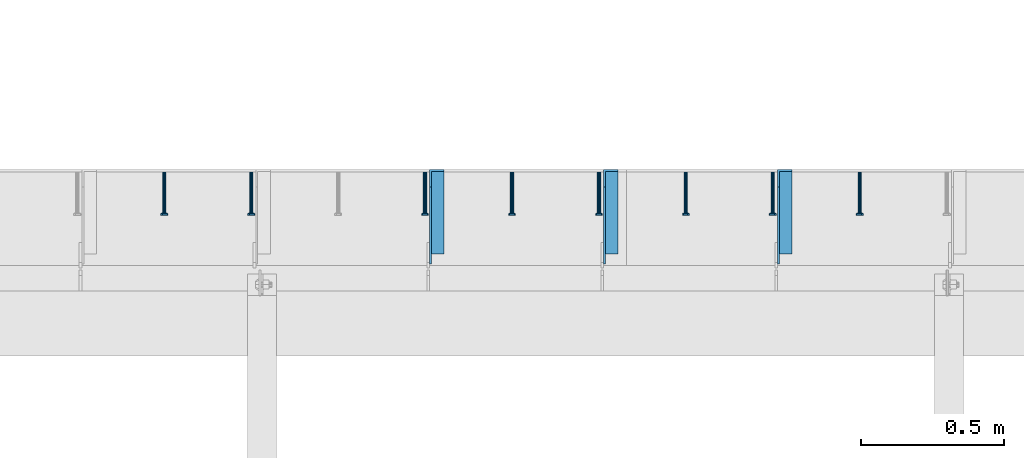
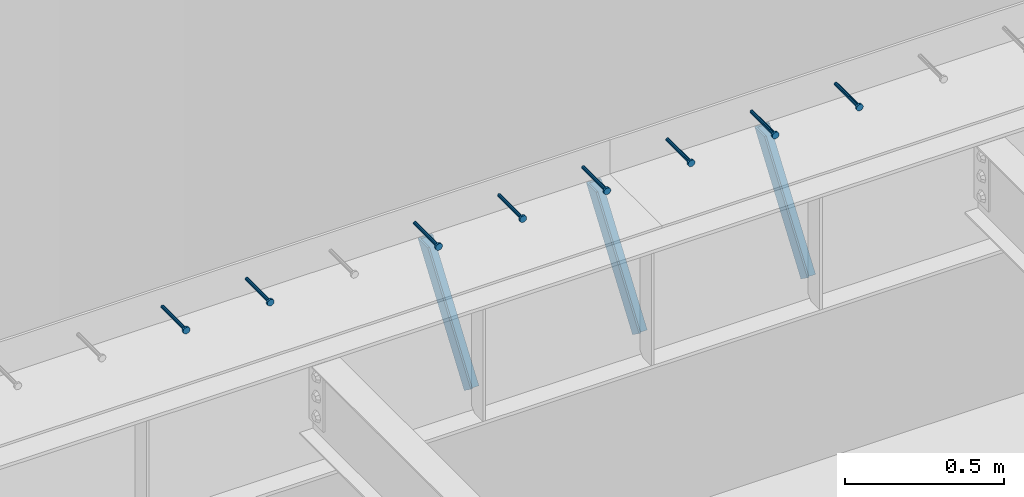
# One storey, part 1357 of 1763: 8 beams, 3 members, 9 elements without a shape of their own.
"""IFC2X3 building model written with IfcOpenShell, lengths in millimetres."""

import ifcopenshell
import ifcopenshell.guid

model = None  # the IFC model being written
_history = None  # IfcOwnerHistory: only IFC2X3 demands one
_inside = {}  # id of a spatial element -> (the spatial element, [elements in it])
_under = {}  # id of a project, library or spatial element -> (it, [spatial elements below it])
_declared = {}  # id of a project -> (the project, [libraries it declares])
_typed = {}  # id of a type object -> (the type object, [elements of that type])
_made_of = {}  # id of a material, layer set ... -> (it, [elements and type objects made of it])


def new_model(schema):
    """Start an empty IFC model of exactly this schema.

    Asked for "IFC4X3", IfcOpenShell would pick the latest addendum, in which some entities
    have other attributes; the version numbers below select the first issue.
    IFC2X3 requires an IfcOwnerHistory on every rooted entity: one is made here for all.
    """
    global model, _history
    if schema == "IFC4X3":
        model = ifcopenshell.file(schema_version=(4, 3, 0, 0))
    else:
        model = ifcopenshell.file(schema=schema)
    _inside.clear()
    _under.clear()
    _declared.clear()
    _typed.clear()
    _made_of.clear()
    _history = None
    if model.schema == "IFC2X3":
        org = make("IfcOrganization", Name="unknown")
        user = make(
            "IfcPersonAndOrganization",
            ThePerson=make("IfcPerson", FamilyName="unknown"),
            TheOrganization=org,
        )
        app = make(
            "IfcApplication",
            ApplicationDeveloper=org,
            Version="unknown",
            ApplicationFullName="unknown",
            ApplicationIdentifier="unknown",
        )
        _history = make(
            "IfcOwnerHistory",
            OwningUser=user,
            OwningApplication=app,
            ChangeAction="ADDED",
            CreationDate=0,
        )
    return model


def make(cls, **values):
    """One entity of the class cls with the attributes given. An attribute that is None is left unset."""
    return model.create_entity(
        cls, **{name: value for name, value in values.items() if value is not None}
    )


def rooted(cls, **values):
    """An entity with a GlobalId (a new one), such as an element, a storey or a relation."""
    return make(cls, GlobalId=ifcopenshell.guid.new(), OwnerHistory=_history, **values)


def si_unit(unit_type, name, prefix=None):
    """IfcSIUnit, for example si_unit("LENGTHUNIT", "METRE", prefix="MILLI")."""
    return make("IfcSIUnit", UnitType=unit_type, Prefix=prefix, Name=name)


def assignment(units):
    """IfcUnitAssignment: the units of a project."""
    return None if units is None else make("IfcUnitAssignment", Units=units)


def point(xyz):
    """IfcCartesianPoint."""
    return None if xyz is None else make("IfcCartesianPoint", Coordinates=xyz)


def direction(xyz):
    """IfcDirection."""
    return None if xyz is None else make("IfcDirection", DirectionRatios=xyz)


def frame(location, z_axis=None, x_axis=None):
    """IfcAxis2Placement3D, a coordinate frame: its origin and axes. An axis left out is left unset."""
    return make(
        "IfcAxis2Placement3D",
        Location=point(location),
        Axis=direction(z_axis),
        RefDirection=direction(x_axis),
    )


def origin_with_axes():
    """The frame at (0, 0, 0) with the z axis (0, 0, 1) and the x axis (1, 0, 0) written out."""
    return frame((0.0, 0.0, 0.0), z_axis=(0.0, 0.0, 1.0), x_axis=(1.0, 0.0, 0.0))


def place(relative_to, where):
    """IfcLocalPlacement: puts the frame where relative to a parent placement (None: the world)."""
    return make(
        "IfcLocalPlacement", PlacementRelTo=relative_to, RelativePlacement=where
    )


def context(
    kind, dimensions, precision=None, world=None, true_north=None, identifier=None
):
    """IfcGeometricRepresentationContext, for example the 3D "Model" context."""
    return make(
        "IfcGeometricRepresentationContext",
        ContextIdentifier=identifier,
        ContextType=kind,
        CoordinateSpaceDimension=dimensions,
        Precision=precision,
        WorldCoordinateSystem=world,
        TrueNorth=true_north,
    )


def subcontext(parent, identifier, kind, view, scale=None):
    """IfcGeometricRepresentationSubContext, for example "Body" below "Model"."""
    return make(
        "IfcGeometricRepresentationSubContext",
        ContextIdentifier=identifier,
        ContextType=kind,
        ParentContext=parent,
        TargetScale=scale,
        TargetView=view,
    )


def project(units=None, contexts=None):
    """IfcProject with its units and contexts."""
    return rooted(
        "IfcProject",
        Name="project",
        RepresentationContexts=contexts,
        UnitsInContext=assignment(units),
    )


def spatial(cls, under=None, at=None, **own):
    """A site, building, storey or space (cls), placed at a placement, below another one or the project."""
    s = rooted(cls, ObjectPlacement=at, **own)
    if under is not None:
        _under.setdefault(under.id(), (under, []))[1].append(s)
    return s


def faces_of(points, faces, orient=None, outer=None):
    """IfcFace entities. A face is a list of loops; a loop is a list of indices into points, from 0.

    orient and outer hold one flag for each loop. By default every Orientation is true, the
    first loop of a face is its IfcFaceOuterBound and the others are IfcFaceBound.
    """
    made = []
    for i, loops in enumerate(faces):
        bounds = []
        for j, loop in enumerate(loops):
            is_outer = j == 0 if outer is None else outer[i][j]
            bounds.append(
                make(
                    "IfcFaceOuterBound" if is_outer else "IfcFaceBound",
                    Bound=make("IfcPolyLoop", Polygon=[points[k] for k in loop]),
                    Orientation=True if orient is None else orient[i][j],
                )
            )
        made.append(make("IfcFace", Bounds=bounds))
    return made


def faceted_brep(points, faces, orient=None, outer=None, voids=None):
    """IfcFacetedBrep: a solid bounded by flat faces; with voids (closed shells), ...WithVoids."""
    shared = [point(p) for p in points]
    hull = make("IfcClosedShell", CfsFaces=faces_of(shared, faces, orient, outer))
    if voids is None:
        return make("IfcFacetedBrep", Outer=hull)
    return make(
        "IfcFacetedBrepWithVoids",
        Outer=hull,
        Voids=[
            make(cls, CfsFaces=faces_of(shared, fs, o, b)) for cls, fs, o, b in voids
        ],
    )


def shape(context_of_items, identifier, shape_type, items):
    """IfcShapeRepresentation: the items that make up one representation, for example the "Body"."""
    return make(
        "IfcShapeRepresentation",
        ContextOfItems=context_of_items,
        RepresentationIdentifier=identifier,
        RepresentationType=shape_type,
        Items=items,
    )


def material(Name=None, Category=None):
    """IfcMaterial."""
    return make("IfcMaterial", Name=Name, Category=Category)


def made_of(thing, what):
    """Note that an element or type object is made of a material, layer set ...; save() writes the relation."""
    if what is not None:
        _made_of.setdefault(what.id(), (what, []))[1].append(thing)
    return thing


def type_object(cls, material=None, **own):
    """A type object (cls), such as IfcWallType, which elements share."""
    return made_of(rooted(cls, **own), material)


def element(
    cls,
    number,
    at=None,
    inside=None,
    cuts=None,
    type_object=None,
    material=None,
    context=None,
    identifier="Body",
    shape_type=None,
    held_by="IfcProductDefinitionShape",
    body=None,
    shapes=None,
    **own,
):
    """One element of the class cls, such as IfcWall. Its Tag is "e" and its number.

    at: its placement. inside: the storey or other place that contains it. cuts: it is an
    opening in that element (IfcRelVoidsElement). A single representation is given by context,
    identifier, shape_type and body (its items); several are given by shapes. held_by: the class
    of the entity that holds the representations. save() writes the other relations.
    """
    e = rooted(cls, Tag="e%d" % number, ObjectPlacement=at, **own)
    if body is not None:
        shapes = [shape(context, identifier, shape_type, body)]
    if shapes is not None:
        e.Representation = make(held_by, Representations=shapes)
    if inside is not None:
        _inside.setdefault(inside.id(), (inside, []))[1].append(e)
    if cuts is not None:
        rooted(
            "IfcRelVoidsElement", RelatingBuildingElement=cuts, RelatedOpeningElement=e
        )
    if type_object is not None:
        _typed.setdefault(type_object.id(), (type_object, []))[1].append(e)
    return made_of(e, material)


def aggregate(whole, parts):
    """IfcRelAggregates: a whole, such as a stair, and the parts it consists of."""
    return rooted("IfcRelAggregates", RelatingObject=whole, RelatedObjects=parts)


def save(model, path):
    """Write the relations noted so far, then the file.

    IfcRelAggregates (storeys below a building ...), IfcRelContainedInSpatialStructure (elements
    in a storey), IfcRelDefinesByType, IfcRelAssociatesMaterial and IfcRelDeclares: one each for
    every whole, place, type object, material and project.
    """
    for whole, parts in _under.values():
        aggregate(whole, parts)
    for where, things in _inside.values():
        rooted(
            "IfcRelContainedInSpatialStructure",
            RelatedElements=things,
            RelatingStructure=where,
        )
    for kind, things in _typed.values():
        rooted("IfcRelDefinesByType", RelatedObjects=things, RelatingType=kind)
    for what, things in _made_of.values():
        rooted("IfcRelAssociatesMaterial", RelatedObjects=things, RelatingMaterial=what)
    for by, libraries in _declared.values():
        rooted("IfcRelDeclares", RelatingContext=by, RelatedDefinitions=libraries)
    model.write(path)


model = new_model("IFC2X3")

# Units and contexts
model_context = context("Model", 3, precision=1e-05, world=origin_with_axes())
body_context = subcontext(model_context, "Body", "Model", "MODEL_VIEW")
ifc_project = project(units=[si_unit("LENGTHUNIT", "METRE", prefix="MILLI"), si_unit("AREAUNIT", "SQUARE_METRE"), si_unit("VOLUMEUNIT", "CUBIC_METRE"), si_unit("MASSUNIT", "GRAM", prefix="KILO"), si_unit("TIMEUNIT", "SECOND"), si_unit("PLANEANGLEUNIT", "RADIAN"), si_unit("SOLIDANGLEUNIT", "STERADIAN"), si_unit("THERMODYNAMICTEMPERATUREUNIT", "DEGREE_CELSIUS"), si_unit("LUMINOUSINTENSITYUNIT", "LUMEN")], contexts=[model_context])

# Site, building, storey
site_placement = place(None, origin_with_axes())
site = spatial("IfcSite", under=ifc_project, at=site_placement, CompositionType="ELEMENT")
building_placement = place(site_placement, origin_with_axes())
building = spatial("IfcBuilding", under=site, at=building_placement, Name="Undefined", CompositionType="ELEMENT")
storey_placement = place(building_placement, origin_with_axes())
storey = spatial("IfcBuildingStorey", under=building, at=storey_placement, Name="Undefined", CompositionType="ELEMENT", Elevation=0.0)

# Assembly, beam
assembly_1_placement = place(storey_placement, origin_with_axes())
assembly_1 = element("IfcElementAssembly", 1, at=assembly_1_placement, inside=storey, Name="HEADED STUD ANCHOR", AssemblyPlace="NOTDEFINED", PredefinedType="RIGID_FRAME")
ifc_material_1 = material(Name="STEEL/A108")
beam_type = type_object("IfcBeamType", PredefinedType="NOTDEFINED")
beam_1_placement = place(assembly_1_placement, frame((-42488.8747736983, 53984.5250183106, 5264.23140606069), z_axis=(0.0, 0.0, 1.0), x_axis=(0.0, -1.0, 0.0)))
beam_1 = element("IfcBeam", 2, at=beam_1_placement, type_object=beam_type, material=ifc_material_1, Name="HEADED STUD ANCHOR", context=body_context, shape_type="Brep", body=[
    faceted_brep([(0.0, -3.1800000667572, 5.5), (0.0, -5.5, 3.1800000667572), (141.732000000002, -5.5, 3.1800000667572), (141.732000000002, -3.1800000667572, 5.5), (0.0, -6.34999999999491, 1.45519152283669e-11), (141.732000000002, -6.34999990463257, 0.0), (0.0, -5.5, -3.1800000667572), (141.732000000002, -5.5, -3.1800000667572), (0.0, -3.1800000667572, -5.5), (141.732000000002, -3.1800000667572, -5.5), (0.0, 0.0, -6.34999990463257), (141.732000000002, 0.0, -6.34999990463257), (0.0, 3.1800000667572, -5.5), (141.732000000002, 3.1800000667572, -5.5), (0.0, 5.5, -3.1800000667572), (141.732000000002, 5.5, -3.1800000667572), (0.0, 6.34999999999491, -2.91038304567337e-11), (141.732000000002, 6.34999990463257, 0.0), (0.0, 5.5, 3.1800000667572), (141.732000000002, 5.5, 3.1800000667572), (0.0, 3.1800000667572, 5.5), (141.732000000002, 3.1800000667572, 5.5), (0.0, 0.0, 6.34999990463257), (141.732000000002, 0.0, 6.34999990463257), (144.780000000001, -10.9899997711182, 6.34999990463257), (144.780000000001, -6.34000015258789, 10.9899997711182), (144.780000000001, -12.6999998092651, 0.0), (144.780000000001, -10.9899997711182, -6.34999990463257), (144.780000000001, -6.34000015258789, -10.9899997711182), (144.780000000001, 0.0, -12.6899995803833), (144.780000000001, 6.34000015258789, -10.9899997711182), (144.780000000001, 10.9899997711182, -6.34999990463257), (144.780000000001, 12.6999998092651, 0.0), (144.780000000001, 10.9899997711182, 6.34999990463257), (144.780000000001, 6.34000015258789, 10.9899997711182), (144.780000000001, 0.0, 12.6899995803833), (152.400000000001, -10.9899997711182, 6.34999990463257), (152.400000000001, -6.34000015258789, 10.9899997711182), (152.400000000001, -12.6999998092651, 0.0), (152.400000000001, -10.9899997711182, -6.34999990463257), (152.400000000001, -6.34000015258789, -10.9899997711182), (152.400000000001, 0.0, -12.6899995803833), (152.400000000001, 6.34000015258789, -10.9899997711182), (152.400000000001, 10.9899997711182, -6.34999990463257), (152.400000000001, 12.6999998092651, 0.0), (152.400000000001, 10.9899997711182, 6.34999990463257), (152.400000000001, 6.34000015258789, 10.9899997711182), (152.400000000001, 0.0, 12.6899995803833)], [[[0, 1, 2, 3]], [[1, 4, 5, 2]], [[4, 6, 7, 5]], [[6, 8, 9, 7]], [[8, 10, 11, 9]], [[10, 12, 13, 11]], [[12, 14, 15, 13]], [[14, 16, 17, 15]], [[16, 18, 19, 17]], [[18, 20, 21, 19]], [[20, 22, 23, 21]], [[22, 0, 3, 23]], [[22, 20, 18, 16, 14, 12, 10, 8, 6, 4, 1, 0]], [[3, 2, 24, 25]], [[2, 5, 26, 24]], [[5, 7, 27, 26]], [[7, 9, 28, 27]], [[9, 11, 29, 28]], [[11, 13, 30, 29]], [[13, 15, 31, 30]], [[15, 17, 32, 31]], [[17, 19, 33, 32]], [[19, 21, 34, 33]], [[21, 23, 35, 34]], [[23, 3, 25, 35]], [[25, 24, 36, 37]], [[24, 26, 38, 36]], [[26, 27, 39, 38]], [[27, 28, 40, 39]], [[28, 29, 41, 40]], [[29, 30, 42, 41]], [[30, 31, 43, 42]], [[31, 32, 44, 43]], [[32, 33, 45, 44]], [[33, 34, 46, 45]], [[34, 35, 47, 46]], [[35, 25, 37, 47]], [[38, 39, 40, 41, 42, 43, 44, 45, 46, 47, 37, 36]]]),
])
aggregate(assembly_1, [beam_1])

assembly_2_placement = place(storey_placement, origin_with_axes())
assembly_2 = element("IfcElementAssembly", 3, at=assembly_2_placement, inside=storey, Name="HEADED STUD ANCHOR", AssemblyPlace="NOTDEFINED", PredefinedType="RIGID_FRAME")
beam_2_placement = place(assembly_2_placement, frame((-42793.6747736983, 53984.5250183106, 5264.23140606069), z_axis=(0.0, 0.0, 1.0), x_axis=(0.0, -1.0, 0.0)))
beam_2 = element("IfcBeam", 4, at=beam_2_placement, type_object=beam_type, material=ifc_material_1, Name="HEADED STUD ANCHOR", context=body_context, shape_type="Brep", body=[
    faceted_brep([(0.0, -3.1800000667572, 5.5), (0.0, -5.5, 3.1800000667572), (141.732000000002, -5.5, 3.1800000667572), (141.732000000002, -3.1800000667572, 5.5), (0.0, -6.34999999999491, 1.45519152283669e-11), (141.732000000002, -6.34999990463257, 0.0), (0.0, -5.5, -3.1800000667572), (141.732000000002, -5.5, -3.1800000667572), (0.0, -3.1800000667572, -5.5), (141.732000000002, -3.1800000667572, -5.5), (0.0, 0.0, -6.34999990463257), (141.732000000002, 0.0, -6.34999990463257), (0.0, 3.1800000667572, -5.5), (141.732000000002, 3.1800000667572, -5.5), (0.0, 5.5, -3.1800000667572), (141.732000000002, 5.5, -3.1800000667572), (0.0, 6.34999999999491, -2.91038304567337e-11), (141.732000000002, 6.34999990463257, 0.0), (0.0, 5.5, 3.1800000667572), (141.732000000002, 5.5, 3.1800000667572), (0.0, 3.1800000667572, 5.5), (141.732000000002, 3.1800000667572, 5.5), (0.0, 0.0, 6.34999990463257), (141.732000000002, 0.0, 6.34999990463257), (144.780000000001, -10.9899997711182, 6.34999990463257), (144.780000000001, -6.34000015258789, 10.9899997711182), (144.780000000001, -12.6999998092651, 0.0), (144.780000000001, -10.9899997711182, -6.34999990463257), (144.780000000001, -6.34000015258789, -10.9899997711182), (144.780000000001, 0.0, -12.6899995803833), (144.780000000001, 6.34000015258789, -10.9899997711182), (144.780000000001, 10.9899997711182, -6.34999990463257), (144.780000000001, 12.6999998092651, 0.0), (144.780000000001, 10.9899997711182, 6.34999990463257), (144.780000000001, 6.34000015258789, 10.9899997711182), (144.780000000001, 0.0, 12.6899995803833), (152.400000000001, -10.9899997711182, 6.34999990463257), (152.400000000001, -6.34000015258789, 10.9899997711182), (152.400000000001, -12.6999998092651, 0.0), (152.400000000001, -10.9899997711182, -6.34999990463257), (152.400000000001, -6.34000015258789, -10.9899997711182), (152.400000000001, 0.0, -12.6899995803833), (152.400000000001, 6.34000015258789, -10.9899997711182), (152.400000000001, 10.9899997711182, -6.34999990463257), (152.400000000001, 12.6999998092651, 0.0), (152.400000000001, 10.9899997711182, 6.34999990463257), (152.400000000001, 6.34000015258789, 10.9899997711182), (152.400000000001, 0.0, 12.6899995803833)], [[[0, 1, 2, 3]], [[1, 4, 5, 2]], [[4, 6, 7, 5]], [[6, 8, 9, 7]], [[8, 10, 11, 9]], [[10, 12, 13, 11]], [[12, 14, 15, 13]], [[14, 16, 17, 15]], [[16, 18, 19, 17]], [[18, 20, 21, 19]], [[20, 22, 23, 21]], [[22, 0, 3, 23]], [[22, 20, 18, 16, 14, 12, 10, 8, 6, 4, 1, 0]], [[3, 2, 24, 25]], [[2, 5, 26, 24]], [[5, 7, 27, 26]], [[7, 9, 28, 27]], [[9, 11, 29, 28]], [[11, 13, 30, 29]], [[13, 15, 31, 30]], [[15, 17, 32, 31]], [[17, 19, 33, 32]], [[19, 21, 34, 33]], [[21, 23, 35, 34]], [[23, 3, 25, 35]], [[25, 24, 36, 37]], [[24, 26, 38, 36]], [[26, 27, 39, 38]], [[27, 28, 40, 39]], [[28, 29, 41, 40]], [[29, 30, 42, 41]], [[30, 31, 43, 42]], [[31, 32, 44, 43]], [[32, 33, 45, 44]], [[33, 34, 46, 45]], [[34, 35, 47, 46]], [[35, 25, 37, 47]], [[38, 39, 40, 41, 42, 43, 44, 45, 46, 47, 37, 36]]]),
])
aggregate(assembly_2, [beam_2])

assembly_3_placement = place(storey_placement, origin_with_axes())
assembly_3 = element("IfcElementAssembly", 5, at=assembly_3_placement, inside=storey, Name="HEADED STUD ANCHOR", AssemblyPlace="NOTDEFINED", PredefinedType="RIGID_FRAME")
beam_3_placement = place(assembly_3_placement, frame((-43098.4747736983, 53984.5250183106, 5264.23140606069), z_axis=(0.0, 0.0, 1.0), x_axis=(0.0, -1.0, 0.0)))
beam_3 = element("IfcBeam", 6, at=beam_3_placement, type_object=beam_type, material=ifc_material_1, Name="HEADED STUD ANCHOR", context=body_context, shape_type="Brep", body=[
    faceted_brep([(0.0, -3.1800000667572, 5.5), (0.0, -5.5, 3.1800000667572), (141.732000000002, -5.5, 3.1800000667572), (141.732000000002, -3.1800000667572, 5.5), (0.0, -6.34999999999491, 1.45519152283669e-11), (141.732000000002, -6.34999990463257, 0.0), (0.0, -5.5, -3.1800000667572), (141.732000000002, -5.5, -3.1800000667572), (0.0, -3.1800000667572, -5.5), (141.732000000002, -3.1800000667572, -5.5), (0.0, 0.0, -6.34999990463257), (141.732000000002, 0.0, -6.34999990463257), (0.0, 3.1800000667572, -5.5), (141.732000000002, 3.1800000667572, -5.5), (0.0, 5.5, -3.1800000667572), (141.732000000002, 5.5, -3.1800000667572), (0.0, 6.34999999999491, -2.91038304567337e-11), (141.732000000002, 6.34999990463257, 0.0), (0.0, 5.5, 3.1800000667572), (141.732000000002, 5.5, 3.1800000667572), (0.0, 3.1800000667572, 5.5), (141.732000000002, 3.1800000667572, 5.5), (0.0, 0.0, 6.34999990463257), (141.732000000002, 0.0, 6.34999990463257), (144.780000000001, -10.9899997711182, 6.34999990463257), (144.780000000001, -6.34000015258789, 10.9899997711182), (144.780000000001, -12.6999998092651, 0.0), (144.780000000001, -10.9899997711182, -6.34999990463257), (144.780000000001, -6.34000015258789, -10.9899997711182), (144.780000000001, 0.0, -12.6899995803833), (144.780000000001, 6.34000015258789, -10.9899997711182), (144.780000000001, 10.9899997711182, -6.34999990463257), (144.780000000001, 12.6999998092651, 0.0), (144.780000000001, 10.9899997711182, 6.34999990463257), (144.780000000001, 6.34000015258789, 10.9899997711182), (144.780000000001, 0.0, 12.6899995803833), (152.400000000001, -10.9899997711182, 6.34999990463257), (152.400000000001, -6.34000015258789, 10.9899997711182), (152.400000000001, -12.6999998092651, 0.0), (152.400000000001, -10.9899997711182, -6.34999990463257), (152.400000000001, -6.34000015258789, -10.9899997711182), (152.400000000001, 0.0, -12.6899995803833), (152.400000000001, 6.34000015258789, -10.9899997711182), (152.400000000001, 10.9899997711182, -6.34999990463257), (152.400000000001, 12.6999998092651, 0.0), (152.400000000001, 10.9899997711182, 6.34999990463257), (152.400000000001, 6.34000015258789, 10.9899997711182), (152.400000000001, 0.0, 12.6899995803833)], [[[0, 1, 2, 3]], [[1, 4, 5, 2]], [[4, 6, 7, 5]], [[6, 8, 9, 7]], [[8, 10, 11, 9]], [[10, 12, 13, 11]], [[12, 14, 15, 13]], [[14, 16, 17, 15]], [[16, 18, 19, 17]], [[18, 20, 21, 19]], [[20, 22, 23, 21]], [[22, 0, 3, 23]], [[22, 20, 18, 16, 14, 12, 10, 8, 6, 4, 1, 0]], [[3, 2, 24, 25]], [[2, 5, 26, 24]], [[5, 7, 27, 26]], [[7, 9, 28, 27]], [[9, 11, 29, 28]], [[11, 13, 30, 29]], [[13, 15, 31, 30]], [[15, 17, 32, 31]], [[17, 19, 33, 32]], [[19, 21, 34, 33]], [[21, 23, 35, 34]], [[23, 3, 25, 35]], [[25, 24, 36, 37]], [[24, 26, 38, 36]], [[26, 27, 39, 38]], [[27, 28, 40, 39]], [[28, 29, 41, 40]], [[29, 30, 42, 41]], [[30, 31, 43, 42]], [[31, 32, 44, 43]], [[32, 33, 45, 44]], [[33, 34, 46, 45]], [[34, 35, 47, 46]], [[35, 25, 37, 47]], [[38, 39, 40, 41, 42, 43, 44, 45, 46, 47, 37, 36]]]),
])
aggregate(assembly_3, [beam_3])

assembly_4_placement = place(storey_placement, origin_with_axes())
assembly_4 = element("IfcElementAssembly", 7, at=assembly_4_placement, inside=storey, Name="HEADED STUD ANCHOR", AssemblyPlace="NOTDEFINED", PredefinedType="RIGID_FRAME")
beam_4_placement = place(assembly_4_placement, frame((-43403.2747736983, 53984.5250183106, 5264.23140606069), z_axis=(0.0, 0.0, 1.0), x_axis=(0.0, -1.0, 0.0)))
beam_4 = element("IfcBeam", 8, at=beam_4_placement, type_object=beam_type, material=ifc_material_1, Name="HEADED STUD ANCHOR", context=body_context, shape_type="Brep", body=[
    faceted_brep([(0.0, -3.1800000667572, 5.5), (0.0, -5.5, 3.1800000667572), (141.732000000002, -5.5, 3.1800000667572), (141.732000000002, -3.1800000667572, 5.5), (0.0, -6.34999999999491, 1.45519152283669e-11), (141.732000000002, -6.34999990463257, 0.0), (0.0, -5.5, -3.1800000667572), (141.732000000002, -5.5, -3.1800000667572), (0.0, -3.1800000667572, -5.5), (141.732000000002, -3.1800000667572, -5.5), (0.0, 0.0, -6.34999990463257), (141.732000000002, 0.0, -6.34999990463257), (0.0, 3.1800000667572, -5.5), (141.732000000002, 3.1800000667572, -5.5), (0.0, 5.5, -3.1800000667572), (141.732000000002, 5.5, -3.1800000667572), (0.0, 6.34999999999491, -2.91038304567337e-11), (141.732000000002, 6.34999990463257, 0.0), (0.0, 5.5, 3.1800000667572), (141.732000000002, 5.5, 3.1800000667572), (0.0, 3.1800000667572, 5.5), (141.732000000002, 3.1800000667572, 5.5), (0.0, 0.0, 6.34999990463257), (141.732000000002, 0.0, 6.34999990463257), (144.780000000001, -10.9899997711182, 6.34999990463257), (144.780000000001, -6.34000015258789, 10.9899997711182), (144.780000000001, -12.6999998092651, 0.0), (144.780000000001, -10.9899997711182, -6.34999990463257), (144.780000000001, -6.34000015258789, -10.9899997711182), (144.780000000001, 0.0, -12.6899995803833), (144.780000000001, 6.34000015258789, -10.9899997711182), (144.780000000001, 10.9899997711182, -6.34999990463257), (144.780000000001, 12.6999998092651, 0.0), (144.780000000001, 10.9899997711182, 6.34999990463257), (144.780000000001, 6.34000015258789, 10.9899997711182), (144.780000000001, 0.0, 12.6899995803833), (152.400000000001, -10.9899997711182, 6.34999990463257), (152.400000000001, -6.34000015258789, 10.9899997711182), (152.400000000001, -12.6999998092651, 0.0), (152.400000000001, -10.9899997711182, -6.34999990463257), (152.400000000001, -6.34000015258789, -10.9899997711182), (152.400000000001, 0.0, -12.6899995803833), (152.400000000001, 6.34000015258789, -10.9899997711182), (152.400000000001, 10.9899997711182, -6.34999990463257), (152.400000000001, 12.6999998092651, 0.0), (152.400000000001, 10.9899997711182, 6.34999990463257), (152.400000000001, 6.34000015258789, 10.9899997711182), (152.400000000001, 0.0, 12.6899995803833)], [[[0, 1, 2, 3]], [[1, 4, 5, 2]], [[4, 6, 7, 5]], [[6, 8, 9, 7]], [[8, 10, 11, 9]], [[10, 12, 13, 11]], [[12, 14, 15, 13]], [[14, 16, 17, 15]], [[16, 18, 19, 17]], [[18, 20, 21, 19]], [[20, 22, 23, 21]], [[22, 0, 3, 23]], [[22, 20, 18, 16, 14, 12, 10, 8, 6, 4, 1, 0]], [[3, 2, 24, 25]], [[2, 5, 26, 24]], [[5, 7, 27, 26]], [[7, 9, 28, 27]], [[9, 11, 29, 28]], [[11, 13, 30, 29]], [[13, 15, 31, 30]], [[15, 17, 32, 31]], [[17, 19, 33, 32]], [[19, 21, 34, 33]], [[21, 23, 35, 34]], [[23, 3, 25, 35]], [[25, 24, 36, 37]], [[24, 26, 38, 36]], [[26, 27, 39, 38]], [[27, 28, 40, 39]], [[28, 29, 41, 40]], [[29, 30, 42, 41]], [[30, 31, 43, 42]], [[31, 32, 44, 43]], [[32, 33, 45, 44]], [[33, 34, 46, 45]], [[34, 35, 47, 46]], [[35, 25, 37, 47]], [[38, 39, 40, 41, 42, 43, 44, 45, 46, 47, 37, 36]]]),
])
aggregate(assembly_4, [beam_4])

assembly_5_placement = place(storey_placement, origin_with_axes())
assembly_5 = element("IfcElementAssembly", 9, at=assembly_5_placement, inside=storey, Name="HEADED STUD ANCHOR", AssemblyPlace="NOTDEFINED", PredefinedType="RIGID_FRAME")
beam_5_placement = place(assembly_5_placement, frame((-43708.0747736983, 53984.5250183106, 5264.23140606069), z_axis=(0.0, 0.0, 1.0), x_axis=(0.0, -1.0, 0.0)))
beam_5 = element("IfcBeam", 10, at=beam_5_placement, type_object=beam_type, material=ifc_material_1, Name="HEADED STUD ANCHOR", context=body_context, shape_type="Brep", body=[
    faceted_brep([(0.0, -3.1800000667572, 5.5), (0.0, -5.5, 3.1800000667572), (141.732000000002, -5.5, 3.1800000667572), (141.732000000002, -3.1800000667572, 5.5), (0.0, -6.34999999999491, 1.45519152283669e-11), (141.732000000002, -6.34999990463257, 0.0), (0.0, -5.5, -3.1800000667572), (141.732000000002, -5.5, -3.1800000667572), (0.0, -3.1800000667572, -5.5), (141.732000000002, -3.1800000667572, -5.5), (0.0, 0.0, -6.34999990463257), (141.732000000002, 0.0, -6.34999990463257), (0.0, 3.1800000667572, -5.5), (141.732000000002, 3.1800000667572, -5.5), (0.0, 5.5, -3.1800000667572), (141.732000000002, 5.5, -3.1800000667572), (0.0, 6.34999999999491, -2.91038304567337e-11), (141.732000000002, 6.34999990463257, 0.0), (0.0, 5.5, 3.1800000667572), (141.732000000002, 5.5, 3.1800000667572), (0.0, 3.1800000667572, 5.5), (141.732000000002, 3.1800000667572, 5.5), (0.0, 0.0, 6.34999990463257), (141.732000000002, 0.0, 6.34999990463257), (144.780000000001, -10.9899997711182, 6.34999990463257), (144.780000000001, -6.34000015258789, 10.9899997711182), (144.780000000001, -12.6999998092651, 0.0), (144.780000000001, -10.9899997711182, -6.34999990463257), (144.780000000001, -6.34000015258789, -10.9899997711182), (144.780000000001, 0.0, -12.6899995803833), (144.780000000001, 6.34000015258789, -10.9899997711182), (144.780000000001, 10.9899997711182, -6.34999990463257), (144.780000000001, 12.6999998092651, 0.0), (144.780000000001, 10.9899997711182, 6.34999990463257), (144.780000000001, 6.34000015258789, 10.9899997711182), (144.780000000001, 0.0, 12.6899995803833), (152.400000000001, -10.9899997711182, 6.34999990463257), (152.400000000001, -6.34000015258789, 10.9899997711182), (152.400000000001, -12.6999998092651, 0.0), (152.400000000001, -10.9899997711182, -6.34999990463257), (152.400000000001, -6.34000015258789, -10.9899997711182), (152.400000000001, 0.0, -12.6899995803833), (152.400000000001, 6.34000015258789, -10.9899997711182), (152.400000000001, 10.9899997711182, -6.34999990463257), (152.400000000001, 12.6999998092651, 0.0), (152.400000000001, 10.9899997711182, 6.34999990463257), (152.400000000001, 6.34000015258789, 10.9899997711182), (152.400000000001, 0.0, 12.6899995803833)], [[[0, 1, 2, 3]], [[1, 4, 5, 2]], [[4, 6, 7, 5]], [[6, 8, 9, 7]], [[8, 10, 11, 9]], [[10, 12, 13, 11]], [[12, 14, 15, 13]], [[14, 16, 17, 15]], [[16, 18, 19, 17]], [[18, 20, 21, 19]], [[20, 22, 23, 21]], [[22, 0, 3, 23]], [[22, 20, 18, 16, 14, 12, 10, 8, 6, 4, 1, 0]], [[3, 2, 24, 25]], [[2, 5, 26, 24]], [[5, 7, 27, 26]], [[7, 9, 28, 27]], [[9, 11, 29, 28]], [[11, 13, 30, 29]], [[13, 15, 31, 30]], [[15, 17, 32, 31]], [[17, 19, 33, 32]], [[19, 21, 34, 33]], [[21, 23, 35, 34]], [[23, 3, 25, 35]], [[25, 24, 36, 37]], [[24, 26, 38, 36]], [[26, 27, 39, 38]], [[27, 28, 40, 39]], [[28, 29, 41, 40]], [[29, 30, 42, 41]], [[30, 31, 43, 42]], [[31, 32, 44, 43]], [[32, 33, 45, 44]], [[33, 34, 46, 45]], [[34, 35, 47, 46]], [[35, 25, 37, 47]], [[38, 39, 40, 41, 42, 43, 44, 45, 46, 47, 37, 36]]]),
])
aggregate(assembly_5, [beam_5])

assembly_6_placement = place(storey_placement, origin_with_axes())
assembly_6 = element("IfcElementAssembly", 11, at=assembly_6_placement, inside=storey, Name="HEADED STUD ANCHOR", AssemblyPlace="NOTDEFINED", PredefinedType="RIGID_FRAME")
beam_6_placement = place(assembly_6_placement, frame((-44012.8747736983, 53984.5250183106, 5264.23140606069), z_axis=(0.0, 0.0, 1.0), x_axis=(0.0, -1.0, 0.0)))
beam_6 = element("IfcBeam", 12, at=beam_6_placement, type_object=beam_type, material=ifc_material_1, Name="HEADED STUD ANCHOR", context=body_context, shape_type="Brep", body=[
    faceted_brep([(0.0, -3.1800000667572, 5.5), (0.0, -5.5, 3.1800000667572), (141.732000000002, -5.5, 3.1800000667572), (141.732000000002, -3.1800000667572, 5.5), (0.0, -6.34999999999491, 1.45519152283669e-11), (141.732000000002, -6.34999990463257, 0.0), (0.0, -5.5, -3.1800000667572), (141.732000000002, -5.5, -3.1800000667572), (0.0, -3.1800000667572, -5.5), (141.732000000002, -3.1800000667572, -5.5), (0.0, 0.0, -6.34999990463257), (141.732000000002, 0.0, -6.34999990463257), (0.0, 3.1800000667572, -5.5), (141.732000000002, 3.1800000667572, -5.5), (0.0, 5.5, -3.1800000667572), (141.732000000002, 5.5, -3.1800000667572), (0.0, 6.34999999999491, -2.91038304567337e-11), (141.732000000002, 6.34999990463257, 0.0), (0.0, 5.5, 3.1800000667572), (141.732000000002, 5.5, 3.1800000667572), (0.0, 3.1800000667572, 5.5), (141.732000000002, 3.1800000667572, 5.5), (0.0, 0.0, 6.34999990463257), (141.732000000002, 0.0, 6.34999990463257), (144.780000000001, -10.9899997711182, 6.34999990463257), (144.780000000001, -6.34000015258789, 10.9899997711182), (144.780000000001, -12.6999998092651, 0.0), (144.780000000001, -10.9899997711182, -6.34999990463257), (144.780000000001, -6.34000015258789, -10.9899997711182), (144.780000000001, 0.0, -12.6899995803833), (144.780000000001, 6.34000015258789, -10.9899997711182), (144.780000000001, 10.9899997711182, -6.34999990463257), (144.780000000001, 12.6999998092651, 0.0), (144.780000000001, 10.9899997711182, 6.34999990463257), (144.780000000001, 6.34000015258789, 10.9899997711182), (144.780000000001, 0.0, 12.6899995803833), (152.400000000001, -10.9899997711182, 6.34999990463257), (152.400000000001, -6.34000015258789, 10.9899997711182), (152.400000000001, -12.6999998092651, 0.0), (152.400000000001, -10.9899997711182, -6.34999990463257), (152.400000000001, -6.34000015258789, -10.9899997711182), (152.400000000001, 0.0, -12.6899995803833), (152.400000000001, 6.34000015258789, -10.9899997711182), (152.400000000001, 10.9899997711182, -6.34999990463257), (152.400000000001, 12.6999998092651, 0.0), (152.400000000001, 10.9899997711182, 6.34999990463257), (152.400000000001, 6.34000015258789, 10.9899997711182), (152.400000000001, 0.0, 12.6899995803833)], [[[0, 1, 2, 3]], [[1, 4, 5, 2]], [[4, 6, 7, 5]], [[6, 8, 9, 7]], [[8, 10, 11, 9]], [[10, 12, 13, 11]], [[12, 14, 15, 13]], [[14, 16, 17, 15]], [[16, 18, 19, 17]], [[18, 20, 21, 19]], [[20, 22, 23, 21]], [[22, 0, 3, 23]], [[22, 20, 18, 16, 14, 12, 10, 8, 6, 4, 1, 0]], [[3, 2, 24, 25]], [[2, 5, 26, 24]], [[5, 7, 27, 26]], [[7, 9, 28, 27]], [[9, 11, 29, 28]], [[11, 13, 30, 29]], [[13, 15, 31, 30]], [[15, 17, 32, 31]], [[17, 19, 33, 32]], [[19, 21, 34, 33]], [[21, 23, 35, 34]], [[23, 3, 25, 35]], [[25, 24, 36, 37]], [[24, 26, 38, 36]], [[26, 27, 39, 38]], [[27, 28, 40, 39]], [[28, 29, 41, 40]], [[29, 30, 42, 41]], [[30, 31, 43, 42]], [[31, 32, 44, 43]], [[32, 33, 45, 44]], [[33, 34, 46, 45]], [[34, 35, 47, 46]], [[35, 25, 37, 47]], [[38, 39, 40, 41, 42, 43, 44, 45, 46, 47, 37, 36]]]),
])
aggregate(assembly_6, [beam_6])

assembly_7_placement = place(storey_placement, origin_with_axes())
assembly_7 = element("IfcElementAssembly", 13, at=assembly_7_placement, inside=storey, Name="HEADED STUD ANCHOR", AssemblyPlace="NOTDEFINED", PredefinedType="RIGID_FRAME")
beam_7_placement = place(assembly_7_placement, frame((-44622.4747736983, 53984.5250183106, 5264.23140606069), z_axis=(0.0, 0.0, 1.0), x_axis=(0.0, -1.0, 0.0)))
beam_7 = element("IfcBeam", 14, at=beam_7_placement, type_object=beam_type, material=ifc_material_1, Name="HEADED STUD ANCHOR", context=body_context, shape_type="Brep", body=[
    faceted_brep([(0.0, -3.1800000667572, 5.5), (0.0, -5.5, 3.1800000667572), (141.732000000002, -5.5, 3.1800000667572), (141.732000000002, -3.1800000667572, 5.5), (0.0, -6.34999999999491, 1.45519152283669e-11), (141.732000000002, -6.34999990463257, 0.0), (0.0, -5.5, -3.1800000667572), (141.732000000002, -5.5, -3.1800000667572), (0.0, -3.1800000667572, -5.5), (141.732000000002, -3.1800000667572, -5.5), (0.0, 0.0, -6.34999990463257), (141.732000000002, 0.0, -6.34999990463257), (0.0, 3.1800000667572, -5.5), (141.732000000002, 3.1800000667572, -5.5), (0.0, 5.5, -3.1800000667572), (141.732000000002, 5.5, -3.1800000667572), (0.0, 6.34999999999491, -2.91038304567337e-11), (141.732000000002, 6.34999990463257, 0.0), (0.0, 5.5, 3.1800000667572), (141.732000000002, 5.5, 3.1800000667572), (0.0, 3.1800000667572, 5.5), (141.732000000002, 3.1800000667572, 5.5), (0.0, 0.0, 6.34999990463257), (141.732000000002, 0.0, 6.34999990463257), (144.780000000001, -10.9899997711182, 6.34999990463257), (144.780000000001, -6.34000015258789, 10.9899997711182), (144.780000000001, -12.6999998092651, 0.0), (144.780000000001, -10.9899997711182, -6.34999990463257), (144.780000000001, -6.34000015258789, -10.9899997711182), (144.780000000001, 0.0, -12.6899995803833), (144.780000000001, 6.34000015258789, -10.9899997711182), (144.780000000001, 10.9899997711182, -6.34999990463257), (144.780000000001, 12.6999998092651, 0.0), (144.780000000001, 10.9899997711182, 6.34999990463257), (144.780000000001, 6.34000015258789, 10.9899997711182), (144.780000000001, 0.0, 12.6899995803833), (152.400000000001, -10.9899997711182, 6.34999990463257), (152.400000000001, -6.34000015258789, 10.9899997711182), (152.400000000001, -12.6999998092651, 0.0), (152.400000000001, -10.9899997711182, -6.34999990463257), (152.400000000001, -6.34000015258789, -10.9899997711182), (152.400000000001, 0.0, -12.6899995803833), (152.400000000001, 6.34000015258789, -10.9899997711182), (152.400000000001, 10.9899997711182, -6.34999990463257), (152.400000000001, 12.6999998092651, 0.0), (152.400000000001, 10.9899997711182, 6.34999990463257), (152.400000000001, 6.34000015258789, 10.9899997711182), (152.400000000001, 0.0, 12.6899995803833)], [[[0, 1, 2, 3]], [[1, 4, 5, 2]], [[4, 6, 7, 5]], [[6, 8, 9, 7]], [[8, 10, 11, 9]], [[10, 12, 13, 11]], [[12, 14, 15, 13]], [[14, 16, 17, 15]], [[16, 18, 19, 17]], [[18, 20, 21, 19]], [[20, 22, 23, 21]], [[22, 0, 3, 23]], [[22, 20, 18, 16, 14, 12, 10, 8, 6, 4, 1, 0]], [[3, 2, 24, 25]], [[2, 5, 26, 24]], [[5, 7, 27, 26]], [[7, 9, 28, 27]], [[9, 11, 29, 28]], [[11, 13, 30, 29]], [[13, 15, 31, 30]], [[15, 17, 32, 31]], [[17, 19, 33, 32]], [[19, 21, 34, 33]], [[21, 23, 35, 34]], [[23, 3, 25, 35]], [[25, 24, 36, 37]], [[24, 26, 38, 36]], [[26, 27, 39, 38]], [[27, 28, 40, 39]], [[28, 29, 41, 40]], [[29, 30, 42, 41]], [[30, 31, 43, 42]], [[31, 32, 44, 43]], [[32, 33, 45, 44]], [[33, 34, 46, 45]], [[34, 35, 47, 46]], [[35, 25, 37, 47]], [[38, 39, 40, 41, 42, 43, 44, 45, 46, 47, 37, 36]]]),
])
aggregate(assembly_7, [beam_7])

assembly_8_placement = place(storey_placement, origin_with_axes())
assembly_8 = element("IfcElementAssembly", 15, at=assembly_8_placement, inside=storey, Name="HEADED STUD ANCHOR", AssemblyPlace="NOTDEFINED", PredefinedType="RIGID_FRAME")
beam_8_placement = place(assembly_8_placement, frame((-44927.2747736983, 53984.5250183106, 5264.23140606069), z_axis=(0.0, 0.0, 1.0), x_axis=(0.0, -1.0, 0.0)))
beam_8 = element("IfcBeam", 16, at=beam_8_placement, type_object=beam_type, material=ifc_material_1, Name="HEADED STUD ANCHOR", context=body_context, shape_type="Brep", body=[
    faceted_brep([(0.0, -3.1800000667572, 5.5), (0.0, -5.5, 3.1800000667572), (141.732000000002, -5.5, 3.1800000667572), (141.732000000002, -3.1800000667572, 5.5), (0.0, -6.34999999999491, 1.45519152283669e-11), (141.732000000002, -6.34999990463257, 0.0), (0.0, -5.5, -3.1800000667572), (141.732000000002, -5.5, -3.1800000667572), (0.0, -3.1800000667572, -5.5), (141.732000000002, -3.1800000667572, -5.5), (0.0, 0.0, -6.34999990463257), (141.732000000002, 0.0, -6.34999990463257), (0.0, 3.1800000667572, -5.5), (141.732000000002, 3.1800000667572, -5.5), (0.0, 5.5, -3.1800000667572), (141.732000000002, 5.5, -3.1800000667572), (0.0, 6.34999999999491, -2.91038304567337e-11), (141.732000000002, 6.34999990463257, 0.0), (0.0, 5.5, 3.1800000667572), (141.732000000002, 5.5, 3.1800000667572), (0.0, 3.1800000667572, 5.5), (141.732000000002, 3.1800000667572, 5.5), (0.0, 0.0, 6.34999990463257), (141.732000000002, 0.0, 6.34999990463257), (144.780000000001, -10.9899997711182, 6.34999990463257), (144.780000000001, -6.34000015258789, 10.9899997711182), (144.780000000001, -12.6999998092651, 0.0), (144.780000000001, -10.9899997711182, -6.34999990463257), (144.780000000001, -6.34000015258789, -10.9899997711182), (144.780000000001, 0.0, -12.6899995803833), (144.780000000001, 6.34000015258789, -10.9899997711182), (144.780000000001, 10.9899997711182, -6.34999990463257), (144.780000000001, 12.6999998092651, 0.0), (144.780000000001, 10.9899997711182, 6.34999990463257), (144.780000000001, 6.34000015258789, 10.9899997711182), (144.780000000001, 0.0, 12.6899995803833), (152.400000000001, -10.9899997711182, 6.34999990463257), (152.400000000001, -6.34000015258789, 10.9899997711182), (152.400000000001, -12.6999998092651, 0.0), (152.400000000001, -10.9899997711182, -6.34999990463257), (152.400000000001, -6.34000015258789, -10.9899997711182), (152.400000000001, 0.0, -12.6899995803833), (152.400000000001, 6.34000015258789, -10.9899997711182), (152.400000000001, 10.9899997711182, -6.34999990463257), (152.400000000001, 12.6999998092651, 0.0), (152.400000000001, 10.9899997711182, 6.34999990463257), (152.400000000001, 6.34000015258789, 10.9899997711182), (152.400000000001, 0.0, 12.6899995803833)], [[[0, 1, 2, 3]], [[1, 4, 5, 2]], [[4, 6, 7, 5]], [[6, 8, 9, 7]], [[8, 10, 11, 9]], [[10, 12, 13, 11]], [[12, 14, 15, 13]], [[14, 16, 17, 15]], [[16, 18, 19, 17]], [[18, 20, 21, 19]], [[20, 22, 23, 21]], [[22, 0, 3, 23]], [[22, 20, 18, 16, 14, 12, 10, 8, 6, 4, 1, 0]], [[3, 2, 24, 25]], [[2, 5, 26, 24]], [[5, 7, 27, 26]], [[7, 9, 28, 27]], [[9, 11, 29, 28]], [[11, 13, 30, 29]], [[13, 15, 31, 30]], [[15, 17, 32, 31]], [[17, 19, 33, 32]], [[19, 21, 34, 33]], [[21, 23, 35, 34]], [[23, 3, 25, 35]], [[25, 24, 36, 37]], [[24, 26, 38, 36]], [[26, 27, 39, 38]], [[27, 28, 40, 39]], [[28, 29, 41, 40]], [[29, 30, 42, 41]], [[30, 31, 43, 42]], [[31, 32, 44, 43]], [[32, 33, 45, 44]], [[33, 34, 46, 45]], [[34, 35, 47, 46]], [[35, 25, 37, 47]], [[38, 39, 40, 41, 42, 43, 44, 45, 46, 47, 37, 36]]]),
])
aggregate(assembly_8, [beam_8])

# Assembly, members
assembly_9_placement = place(storey_placement, origin_with_axes())
assembly_9 = element("IfcElementAssembly", 17, at=assembly_9_placement, inside=storey, Name="BEAM", AssemblyPlace="NOTDEFINED", PredefinedType="RIGID_FRAME")
ifc_material_2 = material(Name="STEEL/A36")
member_type = type_object("IfcMemberType", Name="L2X2X1/4", PredefinedType="NOTDEFINED")
member_1_placement = place(assembly_9_placement, frame((-42751.8044734054, 53682.708383399, 4801.55161052505), z_axis=(0.0, -0.814117947745209, 0.580699549818259), x_axis=(0.0, 0.58069954981826, 0.814117947745209)))
member_1 = element("IfcMember", 18, at=member_1_placement, type_object=member_type, material=ifc_material_2, Name="ANGLE", ObjectType="L2X2X1/4", context=body_context, shape_type="Brep", body=[
    faceted_brep([(-1.45519152283669e-11, 25.4000000000015, -25.3999999999869), (1.45519152283669e-11, 25.4000000000015, 25.3999999999796), (464.304493432646, 25.4000000000015, 25.3999999991429), (500.539460322936, 25.4000000000015, -25.4000000009546), (1.45519152283669e-11, 19.0499999999993, 25.3999999999796), (464.304493432646, 19.0500000000029, 25.3999999991429), (-7.27595761418343e-12, 19.0499999999993, -19.0499999999956), (496.010089461648, 19.0500000000029, -19.0500000009415), (-7.27595761418343e-12, -25.4000000000015, -19.0499999999956), (496.010089461648, -25.4000000000015, -19.0500000009415), (-1.45519152283669e-11, -25.4000000000015, -25.3999999999869), (500.539460322936, -25.4000000000015, -25.4000000009546)], [[[0, 1, 2, 3]], [[1, 4, 5, 2]], [[4, 6, 7, 5]], [[6, 8, 9, 7]], [[8, 10, 11, 9]], [[10, 0, 3, 11]], [[5, 7, 9, 11, 3, 2]], [[10, 8, 6, 4, 1, 0]]]),
])
member_2_placement = place(assembly_9_placement, frame((-43361.4044734054, 53682.708383399, 4801.55161052505), z_axis=(0.0, -0.814117947745209, 0.580699549818259), x_axis=(0.0, 0.58069954981826, 0.814117947745209)))
member_2 = element("IfcMember", 19, at=member_2_placement, type_object=member_type, material=ifc_material_2, Name="ANGLE", ObjectType="L2X2X1/4", context=body_context, shape_type="Brep", body=[
    faceted_brep([(-1.45519152283669e-11, 25.4000000000015, -25.3999999999869), (1.45519152283669e-11, 25.4000000000015, 25.3999999999796), (464.304493432646, 25.4000000000015, 25.3999999991429), (500.539460322936, 25.4000000000015, -25.4000000009546), (1.45519152283669e-11, 19.0499999999993, 25.3999999999796), (464.304493432646, 19.0500000000029, 25.3999999991429), (-7.27595761418343e-12, 19.0499999999993, -19.0499999999956), (496.010089461648, 19.0500000000029, -19.0500000009415), (-7.27595761418343e-12, -25.4000000000015, -19.0499999999956), (496.010089461648, -25.4000000000015, -19.0500000009415), (-1.45519152283669e-11, -25.4000000000015, -25.3999999999869), (500.539460322936, -25.4000000000015, -25.4000000009546)], [[[0, 1, 2, 3]], [[1, 4, 5, 2]], [[4, 6, 7, 5]], [[6, 8, 9, 7]], [[8, 10, 11, 9]], [[10, 0, 3, 11]], [[5, 7, 9, 11, 3, 2]], [[10, 8, 6, 4, 1, 0]]]),
])
member_3_placement = place(assembly_9_placement, frame((-43971.0044734054, 53682.708383399, 4801.55161052505), z_axis=(0.0, -0.814117947745209, 0.580699549818259), x_axis=(0.0, 0.58069954981826, 0.814117947745209)))
member_3 = element("IfcMember", 20, at=member_3_placement, type_object=member_type, material=ifc_material_2, Name="ANGLE", ObjectType="L2X2X1/4", context=body_context, shape_type="Brep", body=[
    faceted_brep([(-1.45519152283669e-11, 25.4000000000015, -25.3999999999869), (1.45519152283669e-11, 25.4000000000015, 25.3999999999796), (464.304493432646, 25.4000000000015, 25.3999999991429), (500.539460322936, 25.4000000000015, -25.4000000009546), (1.45519152283669e-11, 19.0499999999993, 25.3999999999796), (464.304493432646, 19.0500000000029, 25.3999999991429), (-7.27595761418343e-12, 19.0499999999993, -19.0499999999956), (496.010089461648, 19.0500000000029, -19.0500000009415), (-7.27595761418343e-12, -25.4000000000015, -19.0499999999956), (496.010089461648, -25.4000000000015, -19.0500000009415), (-1.45519152283669e-11, -25.4000000000015, -25.3999999999869), (500.539460322936, -25.4000000000015, -25.4000000009546)], [[[0, 1, 2, 3]], [[1, 4, 5, 2]], [[4, 6, 7, 5]], [[6, 8, 9, 7]], [[8, 10, 11, 9]], [[10, 0, 3, 11]], [[5, 7, 9, 11, 3, 2]], [[10, 8, 6, 4, 1, 0]]]),
])
aggregate(assembly_9, [member_1, member_2, member_3])

save(model, "model.ifc")
